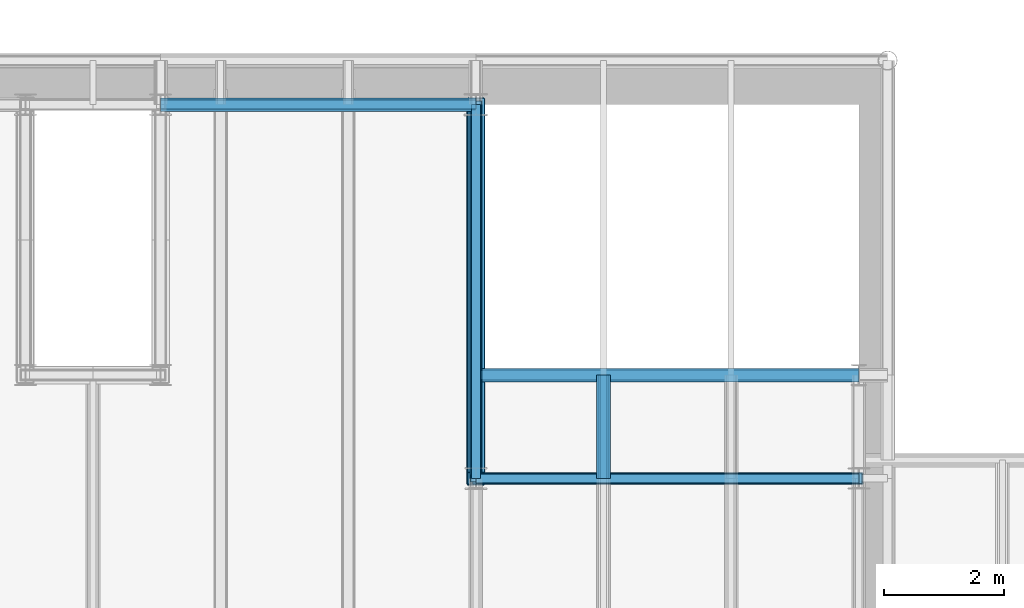
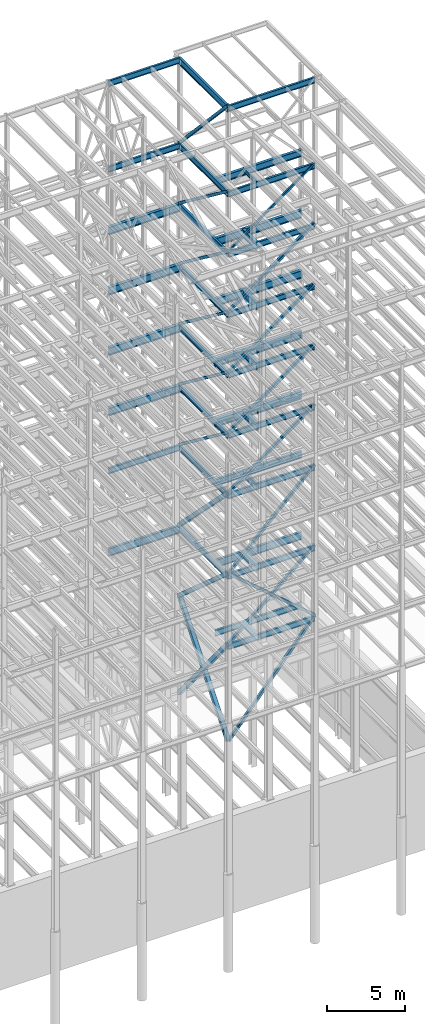
# One storey, part 146 of 150: 60 beams.
"""IFC2X3 building model written with IfcOpenShell, lengths in millimetres."""

from ifc_helpers import new_model, si_unit, frame, origin_with_axes, origin_2d_with_axis, place, context, subcontext, project, spatial, hollow_rectangle, i_section, extrude, material, type_object, element, save


model = new_model("IFC2X3")

# Units and contexts
model_context = context("Model", 3, precision=1e-05, world=origin_with_axes())
body_context = subcontext(model_context, "Body", "Model", "MODEL_VIEW")
ifc_project = project(units=[si_unit("LENGTHUNIT", "METRE", prefix="MILLI"), si_unit("AREAUNIT", "SQUARE_METRE"), si_unit("VOLUMEUNIT", "CUBIC_METRE"), si_unit("MASSUNIT", "GRAM", prefix="KILO"), si_unit("TIMEUNIT", "SECOND"), si_unit("PLANEANGLEUNIT", "RADIAN"), si_unit("SOLIDANGLEUNIT", "STERADIAN"), si_unit("THERMODYNAMICTEMPERATUREUNIT", "DEGREE_CELSIUS"), si_unit("LUMINOUSINTENSITYUNIT", "LUMEN")], contexts=[model_context])

# Site, building, storey
site_placement = place(None, origin_with_axes())
site = spatial("IfcSite", under=ifc_project, at=site_placement, CompositionType="ELEMENT")
building_placement = place(site_placement, origin_with_axes())
building = spatial("IfcBuilding", under=site, at=building_placement, Name="Undefined", CompositionType="ELEMENT")
storey_placement = place(building_placement, origin_with_axes())
storey = spatial("IfcBuildingStorey", under=building, at=storey_placement, Name="Undefined", CompositionType="ELEMENT", Elevation=0.0)

# Beams
ifc_material_1 = material()
beam_type_1 = type_object("IfcBeamType", Name="HSS8X8X3/8", PredefinedType="NOTDEFINED")
for number, where, z_axis, x_axis, name in (
    (1, (82194.4, 25628.6, 40309.8), (-0.593852272176556, 0.0, 0.804574097787607), (0.804574097787604, 0.0, 0.59385227217656), "BEAM"),
    (2, (82194.4, 25628.6, 35585.4), (-0.593852272176556, 0.0, 0.804574097787607), (0.804574097787604, 0.0, 0.59385227217656), "BEAM"),
):
    element("IfcBeam", number, at=place(storey_placement, frame(where, z_axis=z_axis, x_axis=x_axis)), inside=storey, type_object=beam_type_1, material=ifc_material_1, Name=name, ObjectType="HSS8X8X3/8", context=body_context, shape_type="SweptSolid", body=[
        extrude(hollow_rectangle(XDim=203.2, YDim=203.2, WallThickness=9.525, InnerFilletRadius=9.5249, OuterFilletRadius=19.0499, at=origin_2d_with_axis()), frame((7955.51355978985, 0.0, -1.81898940354586e-12), z_axis=(-1.0, 0.0, 0.0), x_axis=(0.0, -1.0, 0.0)), (0.0, 0.0, 1.0), 7955.51355978984),
    ])
ifc_material_2 = material(Name="STEEL/A992")
beam_type_2 = type_object("IfcBeamType", Name="W18X35", PredefinedType="NOTDEFINED")
beam_1_placement = place(storey_placement, frame((82194.4, 25628.6, 65687.575), z_axis=(0.0, 0.0, 1.0), x_axis=(1.0, 0.0, 0.0)))
element("IfcBeam", 3, at=beam_1_placement, inside=storey, type_object=beam_type_2, material=ifc_material_2, Name="BEAM", ObjectType="W18X35", context=body_context, shape_type="SweptSolid", body=[
    extrude(i_section(OverallWidth=152.4, OverallDepth=450.85, WebThickness=7.9375, FlangeThickness=10.795, FilletRadius=17.78, at=origin_2d_with_axis()), frame((6400.80000000001, 0.0, 0.0), z_axis=(-1.0, 0.0, 0.0), x_axis=(0.0, -1.0, 0.0)), (0.0, 0.0, 1.0), 6400.8),
])
beam_2_placement = place(storey_placement, frame((76923.9, 31877.0, 65687.575), z_axis=(0.0, 0.0, 1.0), x_axis=(1.0, 0.0, 0.0)))
element("IfcBeam", 4, at=beam_2_placement, inside=storey, type_object=beam_type_2, material=ifc_material_2, Name="BEAM", ObjectType="W18X35", context=body_context, shape_type="SweptSolid", body=[
    extrude(i_section(OverallWidth=152.4, OverallDepth=450.85, WebThickness=7.9375, FlangeThickness=10.795, FilletRadius=17.78, at=origin_2d_with_axis()), frame((5270.5, 0.0, 0.0), z_axis=(-1.0, 0.0, 0.0), x_axis=(0.0, -1.0, 0.0)), (0.0, 0.0, 1.0), 5270.5),
])
beam_3_placement = place(storey_placement, frame((82194.4, 25628.6, 58981.975), z_axis=(0.0, 0.0, 1.0), x_axis=(1.0, 0.0, 0.0)))
element("IfcBeam", 5, at=beam_3_placement, inside=storey, type_object=beam_type_2, material=ifc_material_2, Name="BEAM", ObjectType="W18X35", context=body_context, shape_type="SweptSolid", body=[
    extrude(i_section(OverallWidth=152.4, OverallDepth=450.85, WebThickness=7.9375, FlangeThickness=10.795, FilletRadius=17.78, at=origin_2d_with_axis()), frame((6400.80000000001, 0.0, 0.0), z_axis=(-1.0, 0.0, 0.0), x_axis=(0.0, -1.0, 0.0)), (0.0, 0.0, 1.0), 6400.8),
])
beam_4_placement = place(storey_placement, frame((82194.4, 25628.6, 58981.975), z_axis=(0.0, 0.0, 1.0), x_axis=(0.0, 1.0, 0.0)))
element("IfcBeam", 6, at=beam_4_placement, inside=storey, type_object=beam_type_2, material=ifc_material_2, Name="BEAM", ObjectType="W18X35", context=body_context, shape_type="SweptSolid", body=[
    extrude(i_section(OverallWidth=152.4, OverallDepth=450.85, WebThickness=7.9375, FlangeThickness=10.795, FilletRadius=17.78, at=origin_2d_with_axis()), frame((6248.40000000001, 0.0, 0.0), z_axis=(-1.0, 0.0, 0.0), x_axis=(0.0, -1.0, 0.0)), (0.0, 0.0, 1.0), 6248.40000000001),
])
beam_5_placement = place(storey_placement, frame((76923.9, 31877.0, 58981.975), z_axis=(0.0, 0.0, 1.0), x_axis=(1.0, 0.0, 0.0)))
element("IfcBeam", 7, at=beam_5_placement, inside=storey, type_object=beam_type_2, material=ifc_material_2, Name="BEAM", ObjectType="W18X35", context=body_context, shape_type="SweptSolid", body=[
    extrude(i_section(OverallWidth=152.4, OverallDepth=450.85, WebThickness=7.9375, FlangeThickness=10.795, FilletRadius=17.78, at=origin_2d_with_axis()), frame((5270.5, 0.0, 0.0), z_axis=(-1.0, 0.0, 0.0), x_axis=(0.0, -1.0, 0.0)), (0.0, 0.0, 1.0), 5270.5),
])
beam_6_placement = place(storey_placement, frame((82194.4, 25628.6, 54257.575), z_axis=(0.0, 0.0, 1.0), x_axis=(1.0, 0.0, 0.0)))
element("IfcBeam", 8, at=beam_6_placement, inside=storey, type_object=beam_type_2, material=ifc_material_2, Name="BEAM", ObjectType="W18X35", context=body_context, shape_type="SweptSolid", body=[
    extrude(i_section(OverallWidth=152.4, OverallDepth=450.85, WebThickness=7.9375, FlangeThickness=10.795, FilletRadius=17.78, at=origin_2d_with_axis()), frame((6400.80000000001, 0.0, 0.0), z_axis=(-1.0, 0.0, 0.0), x_axis=(0.0, -1.0, 0.0)), (0.0, 0.0, 1.0), 6400.8),
])
beam_7_placement = place(storey_placement, frame((82194.4, 31877.0, 54257.575), z_axis=(0.0, 0.0, 1.0), x_axis=(0.0, -1.0, 0.0)))
element("IfcBeam", 9, at=beam_7_placement, inside=storey, type_object=beam_type_2, material=ifc_material_2, Name="BEAM", ObjectType="W18X35", context=body_context, shape_type="SweptSolid", body=[
    extrude(i_section(OverallWidth=152.4, OverallDepth=450.85, WebThickness=7.9375, FlangeThickness=10.795, FilletRadius=17.78, at=origin_2d_with_axis()), frame((6248.40000000001, 0.0, 0.0), z_axis=(-1.0, 0.0, 0.0), x_axis=(0.0, -1.0, 0.0)), (0.0, 0.0, 1.0), 6248.40000000001),
])
beam_8_placement = place(storey_placement, frame((82194.4, 25628.6, 49533.175), z_axis=(0.0, 0.0, 1.0), x_axis=(1.0, 0.0, 0.0)))
element("IfcBeam", 10, at=beam_8_placement, inside=storey, type_object=beam_type_2, material=ifc_material_2, Name="BEAM", ObjectType="W18X35", context=body_context, shape_type="SweptSolid", body=[
    extrude(i_section(OverallWidth=152.4, OverallDepth=450.85, WebThickness=7.9375, FlangeThickness=10.795, FilletRadius=17.78, at=origin_2d_with_axis()), frame((6400.80000000001, 0.0, 0.0), z_axis=(-1.0, 0.0, 0.0), x_axis=(0.0, -1.0, 0.0)), (0.0, 0.0, 1.0), 6400.8),
])
beam_9_placement = place(storey_placement, frame((82194.4, 31877.0, 49533.175), z_axis=(0.0, 0.0, 1.0), x_axis=(0.0, -1.0, 0.0)))
element("IfcBeam", 11, at=beam_9_placement, inside=storey, type_object=beam_type_2, material=ifc_material_2, Name="BEAM", ObjectType="W18X35", context=body_context, shape_type="SweptSolid", body=[
    extrude(i_section(OverallWidth=152.4, OverallDepth=450.85, WebThickness=7.9375, FlangeThickness=10.795, FilletRadius=17.78, at=origin_2d_with_axis()), frame((6248.40000000001, 0.0, 0.0), z_axis=(-1.0, 0.0, 0.0), x_axis=(0.0, -1.0, 0.0)), (0.0, 0.0, 1.0), 6248.40000000001),
])
beam_10_placement = place(storey_placement, frame((82194.4, 25628.6, 44808.775), z_axis=(0.0, 0.0, 1.0), x_axis=(1.0, 0.0, 0.0)))
element("IfcBeam", 12, at=beam_10_placement, inside=storey, type_object=beam_type_2, material=ifc_material_2, Name="BEAM", ObjectType="W18X35", context=body_context, shape_type="SweptSolid", body=[
    extrude(i_section(OverallWidth=152.4, OverallDepth=450.85, WebThickness=7.9375, FlangeThickness=10.795, FilletRadius=17.78, at=origin_2d_with_axis()), frame((6400.80000000001, 0.0, 0.0), z_axis=(-1.0, 0.0, 0.0), x_axis=(0.0, -1.0, 0.0)), (0.0, 0.0, 1.0), 6400.8),
])
beam_11_placement = place(storey_placement, frame((82194.4, 31877.0, 44808.775), z_axis=(0.0, 0.0, 1.0), x_axis=(0.0, -1.0, 0.0)))
element("IfcBeam", 13, at=beam_11_placement, inside=storey, type_object=beam_type_2, material=ifc_material_2, Name="BEAM", ObjectType="W18X35", context=body_context, shape_type="SweptSolid", body=[
    extrude(i_section(OverallWidth=152.4, OverallDepth=450.85, WebThickness=7.9375, FlangeThickness=10.795, FilletRadius=17.78, at=origin_2d_with_axis()), frame((6248.40000000001, 0.0, 0.0), z_axis=(-1.0, 0.0, 0.0), x_axis=(0.0, -1.0, 0.0)), (0.0, 0.0, 1.0), 6248.40000000001),
])
beam_12_placement = place(storey_placement, frame((82194.4, 25628.6, 40084.375), z_axis=(0.0, 0.0, 1.0), x_axis=(1.0, 0.0, 0.0)))
element("IfcBeam", 14, at=beam_12_placement, inside=storey, type_object=beam_type_2, material=ifc_material_2, Name="BEAM", ObjectType="W18X35", context=body_context, shape_type="SweptSolid", body=[
    extrude(i_section(OverallWidth=152.4, OverallDepth=450.85, WebThickness=7.9375, FlangeThickness=10.795, FilletRadius=17.78, at=origin_2d_with_axis()), frame((6400.80000000001, 0.0, 0.0), z_axis=(-1.0, 0.0, 0.0), x_axis=(0.0, -1.0, 0.0)), (0.0, 0.0, 1.0), 6400.8),
])
beam_13_placement = place(storey_placement, frame((82194.4, 31877.0, 40084.375), z_axis=(0.0, 0.0, 1.0), x_axis=(0.0, -1.0, 0.0)))
element("IfcBeam", 15, at=beam_13_placement, inside=storey, type_object=beam_type_2, material=ifc_material_2, Name="BEAM", ObjectType="W18X35", context=body_context, shape_type="SweptSolid", body=[
    extrude(i_section(OverallWidth=152.4, OverallDepth=450.85, WebThickness=7.9375, FlangeThickness=10.795, FilletRadius=17.78, at=origin_2d_with_axis()), frame((6248.40000000001, 0.0, 0.0), z_axis=(-1.0, 0.0, 0.0), x_axis=(0.0, -1.0, 0.0)), (0.0, 0.0, 1.0), 6248.40000000001),
])
beam_14_placement = place(storey_placement, frame((82194.4, 25628.6, 35359.975), z_axis=(0.0, 0.0, 1.0), x_axis=(1.0, 0.0, 0.0)))
element("IfcBeam", 16, at=beam_14_placement, inside=storey, type_object=beam_type_2, material=ifc_material_2, Name="BEAM", ObjectType="W18X35", context=body_context, shape_type="SweptSolid", body=[
    extrude(i_section(OverallWidth=152.4, OverallDepth=450.85, WebThickness=7.9375, FlangeThickness=10.795, FilletRadius=17.78, at=origin_2d_with_axis()), frame((6400.80000000001, 0.0, 0.0), z_axis=(-1.0, 0.0, 0.0), x_axis=(0.0, -1.0, 0.0)), (0.0, 0.0, 1.0), 6400.8),
])
beam_15_placement = place(storey_placement, frame((82194.4, 31877.0, 35359.975), z_axis=(0.0, 0.0, 1.0), x_axis=(0.0, -1.0, 0.0)))
element("IfcBeam", 17, at=beam_15_placement, inside=storey, type_object=beam_type_2, material=ifc_material_2, Name="BEAM", ObjectType="W18X35", context=body_context, shape_type="SweptSolid", body=[
    extrude(i_section(OverallWidth=152.4, OverallDepth=450.85, WebThickness=7.9375, FlangeThickness=10.795, FilletRadius=17.78, at=origin_2d_with_axis()), frame((6248.40000000001, 0.0, 0.0), z_axis=(-1.0, 0.0, 0.0), x_axis=(0.0, -1.0, 0.0)), (0.0, 0.0, 1.0), 6248.40000000001),
])
beam_16_placement = place(storey_placement, frame((76923.9, 31877.0, 35359.975), z_axis=(0.0, 0.0, 1.0), x_axis=(1.0, 0.0, 0.0)))
element("IfcBeam", 18, at=beam_16_placement, inside=storey, type_object=beam_type_2, material=ifc_material_2, Name="BEAM", ObjectType="W18X35", context=body_context, shape_type="SweptSolid", body=[
    extrude(i_section(OverallWidth=152.4, OverallDepth=450.85, WebThickness=7.9375, FlangeThickness=10.795, FilletRadius=17.78, at=origin_2d_with_axis()), frame((5270.5, 0.0, 0.0), z_axis=(-1.0, 0.0, 0.0), x_axis=(0.0, -1.0, 0.0)), (0.0, 0.0, 1.0), 5270.5),
])
beam_17_placement = place(storey_placement, frame((82194.4, 25628.6, 29060.775), z_axis=(0.0, 0.0, 1.0), x_axis=(1.0, 0.0, 0.0)))
element("IfcBeam", 19, at=beam_17_placement, inside=storey, type_object=beam_type_2, material=ifc_material_2, Name="BEAM", ObjectType="W18X35", context=body_context, shape_type="SweptSolid", body=[
    extrude(i_section(OverallWidth=152.4, OverallDepth=450.85, WebThickness=7.9375, FlangeThickness=10.795, FilletRadius=17.78, at=origin_2d_with_axis()), frame((6400.80000000001, 0.0, 0.0), z_axis=(-1.0, 0.0, 0.0), x_axis=(0.0, -1.0, 0.0)), (0.0, 0.0, 1.0), 6400.8),
])
beam_18_placement = place(storey_placement, frame((82194.4, 25628.6, 29060.775), z_axis=(0.0, 0.0, 1.0), x_axis=(0.0, 1.0, 0.0)))
element("IfcBeam", 20, at=beam_18_placement, inside=storey, type_object=beam_type_2, material=ifc_material_2, Name="BEAM", ObjectType="W18X35", context=body_context, shape_type="SweptSolid", body=[
    extrude(i_section(OverallWidth=152.4, OverallDepth=450.85, WebThickness=7.9375, FlangeThickness=10.795, FilletRadius=17.78, at=origin_2d_with_axis()), frame((6248.40000000001, 0.0, 0.0), z_axis=(-1.0, 0.0, 0.0), x_axis=(0.0, -1.0, 0.0)), (0.0, 0.0, 1.0), 6248.40000000001),
])
beam_19_placement = place(storey_placement, frame((82194.4, 27355.8, 23548.975), z_axis=(0.0, 0.0, 1.0), x_axis=(1.0, 0.0, 0.0)))
element("IfcBeam", 21, at=beam_19_placement, inside=storey, type_object=beam_type_2, material=ifc_material_2, Name="BEAM", ObjectType="W18X35", context=body_context, shape_type="SweptSolid", body=[
    extrude(i_section(OverallWidth=152.4, OverallDepth=450.85, WebThickness=7.9375, FlangeThickness=10.795, FilletRadius=17.78, at=origin_2d_with_axis()), frame((6400.80000000001, 0.0, 0.0), z_axis=(-1.0, 0.0, 0.0), x_axis=(0.0, -1.0, 0.0)), (0.0, 0.0, 1.0), 6400.8),
])
beam_20_placement = place(storey_placement, frame((84328.0, 25628.6, 23548.975), z_axis=(0.0, 0.0, 1.0), x_axis=(0.0, 1.0, 0.0)))
element("IfcBeam", 22, at=beam_20_placement, inside=storey, type_object=beam_type_2, material=ifc_material_2, Name="BEAM", ObjectType="W18X35", context=body_context, shape_type="SweptSolid", body=[
    extrude(i_section(OverallWidth=152.4, OverallDepth=450.85, WebThickness=7.9375, FlangeThickness=10.795, FilletRadius=17.78, at=origin_2d_with_axis()), frame((1727.2, 0.0, 0.0), z_axis=(-1.0, 0.0, 0.0), x_axis=(0.0, -1.0, 0.0)), (0.0, 0.0, 1.0), 1727.2),
])
beam_21_placement = place(storey_placement, frame((82194.4, 25628.6, 23548.975), z_axis=(0.0, 0.0, 1.0), x_axis=(1.0, 0.0, 0.0)))
element("IfcBeam", 23, at=beam_21_placement, inside=storey, type_object=beam_type_2, material=ifc_material_2, Name="BEAM", ObjectType="W18X35", context=body_context, shape_type="SweptSolid", body=[
    extrude(i_section(OverallWidth=152.4, OverallDepth=450.85, WebThickness=7.9375, FlangeThickness=10.795, FilletRadius=17.78, at=origin_2d_with_axis()), frame((6400.80000000001, 0.0, 0.0), z_axis=(-1.0, 0.0, 0.0), x_axis=(0.0, -1.0, 0.0)), (0.0, 0.0, 1.0), 6400.8),
])
beam_type_3 = type_object("IfcBeamType", Name="HSS8X8X1/4", PredefinedType="NOTDEFINED")
beam_22_placement = place(storey_placement, frame((82194.4, 31877.0, 59207.4), z_axis=(0.0, 0.73160793181113, 0.681725629642191), x_axis=(0.0, -0.681725629642191, 0.731607931811129)))
element("IfcBeam", 24, at=beam_22_placement, inside=storey, type_object=beam_type_3, material=ifc_material_1, Name="BEAM", ObjectType="HSS8X8X1/4", context=body_context, shape_type="SweptSolid", body=[
    extrude(hollow_rectangle(XDim=203.2, YDim=203.2, WallThickness=6.35, InnerFilletRadius=6.3499, OuterFilletRadius=12.6999, at=origin_2d_with_axis()), frame((9165.56427236196, 0.0, -1.0175820488858e-12), z_axis=(-1.0, 0.0, 0.0), x_axis=(0.0, -1.0, 0.0)), (0.0, 0.0, 1.0), 9165.56427236196),
])
for number, where, z_axis, x_axis, name in (
    (25, (82194.4, 31877.0, 54483.0), (0.0, 0.603108242282795, 0.797659355922412), (0.0, -0.797659355922412, 0.603108242282795), "BEAM"),
    (26, (82194.4, 31877.0, 49758.6), (0.0, 0.603108242282795, 0.797659355922412), (0.0, -0.797659355922412, 0.603108242282795), "BEAM"),
):
    element("IfcBeam", number, at=place(storey_placement, frame(where, z_axis=z_axis, x_axis=x_axis)), inside=storey, type_object=beam_type_3, material=ifc_material_1, Name=name, ObjectType="HSS8X8X1/4", context=body_context, shape_type="SweptSolid", body=[
        extrude(hollow_rectangle(XDim=203.2, YDim=203.2, WallThickness=6.35, InnerFilletRadius=6.3499, OuterFilletRadius=12.6999, at=origin_2d_with_axis()), frame((7833.41929938644, 0.0, 0.0), z_axis=(-1.0, 0.0, 0.0), x_axis=(0.0, -1.0, 0.0)), (0.0, 0.0, 1.0), 7833.41929938644),
    ])
for number, where, z_axis, x_axis, name in (
    (27, (82194.4, 25628.6, 49758.6), (-0.593852272176556, 0.0, 0.804574097787607), (0.804574097787604, 0.0, 0.59385227217656), "BEAM"),
    (28, (82194.4, 25628.6, 45034.2), (-0.593852272176556, 0.0, 0.804574097787607), (0.804574097787604, 0.0, 0.59385227217656), "BEAM"),
):
    element("IfcBeam", number, at=place(storey_placement, frame(where, z_axis=z_axis, x_axis=x_axis)), inside=storey, type_object=beam_type_3, material=ifc_material_1, Name=name, ObjectType="HSS8X8X1/4", context=body_context, shape_type="SweptSolid", body=[
        extrude(hollow_rectangle(XDim=203.2, YDim=203.2, WallThickness=6.35, InnerFilletRadius=6.3499, OuterFilletRadius=12.6999, at=origin_2d_with_axis()), frame((7955.51355978985, 0.0, -1.81898940354586e-12), z_axis=(-1.0, 0.0, 0.0), x_axis=(0.0, -1.0, 0.0)), (0.0, 0.0, 1.0), 7955.51355978984),
    ])
beam_type_4 = type_object("IfcBeamType", Name="HSS12X12X5/8", PredefinedType="NOTDEFINED")
beam_23_placement = place(storey_placement, frame((82194.4, 31877.0, 29286.2), z_axis=(0.0, 0.709963736329935, 0.704238236036952), x_axis=(0.0, -0.704238236036953, 0.709963736329935)))
element("IfcBeam", 29, at=beam_23_placement, inside=storey, type_object=beam_type_4, material=ifc_material_1, Name="BEAM", ObjectType="HSS12X12X5/8", context=body_context, shape_type="SweptSolid", body=[
    extrude(hollow_rectangle(XDim=304.8, YDim=304.8, WallThickness=15.875, InnerFilletRadius=15.875, OuterFilletRadius=31.75, at=origin_2d_with_axis()), frame((8872.56576194282, 0.0, 0.0), z_axis=(-1.0, 0.0, 0.0), x_axis=(0.0, -1.0, 0.0)), (0.0, 0.0, 1.0), 8872.56576194282),
])
beam_24_placement = place(storey_placement, frame((82194.4, 31877.0, 23774.4), z_axis=(0.0, 0.661520808536634, 0.749926809677477), x_axis=(0.0, -0.749926809677476, 0.661520808536635)))
element("IfcBeam", 30, at=beam_24_placement, inside=storey, type_object=beam_type_4, material=ifc_material_1, Name="BEAM", ObjectType="HSS12X12X5/8", context=body_context, shape_type="SweptSolid", body=[
    extrude(hollow_rectangle(XDim=304.8, YDim=304.8, WallThickness=15.875, InnerFilletRadius=15.875, OuterFilletRadius=31.75, at=origin_2d_with_axis()), frame((8332.01307008096, 0.0, -9.25039275188162e-13), z_axis=(-1.0, 0.0, 0.0), x_axis=(0.0, -1.0, 0.0)), (0.0, 0.0, 1.0), 8332.01307008096),
])
for number, where, z_axis, x_axis, name in (
    (31, (82194.4, 25628.6, 16154.4), (0.0, -0.773267797360785, 0.634079579835843), (0.0, 0.634079579835843, 0.773267797360786), "BEAM"),
    (32, (82194.4, 31877.0, 16154.4), (0.0, 0.773267797360785, 0.634079579835843), (0.0, -0.634079579835843, 0.773267797360786), "BEAM"),
):
    element("IfcBeam", number, at=place(storey_placement, frame(where, z_axis=z_axis, x_axis=x_axis)), inside=storey, type_object=beam_type_4, material=ifc_material_1, Name=name, ObjectType="HSS12X12X5/8", context=body_context, shape_type="SweptSolid", body=[
        extrude(hollow_rectangle(XDim=304.8, YDim=304.8, WallThickness=15.875, InnerFilletRadius=15.875, OuterFilletRadius=31.75, at=origin_2d_with_axis()), frame((9854.28346253547, 0.0, 5.47022619564489e-13), z_axis=(-1.0, 0.0, 0.0), x_axis=(0.0, -1.0, 0.0)), (0.0, 0.0, 1.0), 9854.28346253547),
    ])
beam_type_5 = type_object("IfcBeamType", Name="HSS8X8X1/2", PredefinedType="NOTDEFINED")
for number, where, z_axis, x_axis, name in (
    (33, (82194.4, 31877.0, 45034.2), (0.0, 0.603108242282795, 0.797659355922412), (0.0, -0.797659355922412, 0.603108242282795), "BEAM"),
    (34, (82194.4, 31877.0, 40309.8), (0.0, 0.603108242282795, 0.797659355922412), (0.0, -0.797659355922412, 0.603108242282795), "BEAM"),
    (35, (82194.4, 31877.0, 35585.4), (0.0, 0.603108242282795, 0.797659355922412), (0.0, -0.797659355922412, 0.603108242282795), "BEAM"),
):
    element("IfcBeam", number, at=place(storey_placement, frame(where, z_axis=z_axis, x_axis=x_axis)), inside=storey, type_object=beam_type_5, material=ifc_material_1, Name=name, ObjectType="HSS8X8X1/2", context=body_context, shape_type="SweptSolid", body=[
        extrude(hollow_rectangle(XDim=203.2, YDim=203.2, WallThickness=12.7, InnerFilletRadius=12.6999, OuterFilletRadius=25.3999, at=origin_2d_with_axis()), frame((7833.41929938644, 0.0, 0.0), z_axis=(-1.0, 0.0, 0.0), x_axis=(0.0, -1.0, 0.0)), (0.0, 0.0, 1.0), 7833.41929938644),
    ])
beam_25_placement = place(storey_placement, frame((82194.4, 25628.6, 29286.2), z_axis=(-0.701427454200915, 0.0, 0.712740855075127), x_axis=(0.712740855075127, 0.0, 0.701427454200915)))
element("IfcBeam", 36, at=beam_25_placement, inside=storey, type_object=beam_type_5, material=ifc_material_1, Name="BEAM", ObjectType="HSS8X8X1/2", context=body_context, shape_type="SweptSolid", body=[
    extrude(hollow_rectangle(XDim=203.2, YDim=203.2, WallThickness=12.7, InnerFilletRadius=12.6999, OuterFilletRadius=25.3999, at=origin_2d_with_axis()), frame((8980.54348466728, 3.63797880709171e-12, -8.27299822921593e-12), z_axis=(-1.0, 0.0, 0.0), x_axis=(0.0, -1.0, 0.0)), (0.0, 0.0, 1.0), 8980.54348466728),
])
for number, where, z_axis, x_axis, name in (
    (37, (82194.4, 25628.6, 23774.4), (-0.652523116219427, 0.0, 0.75776881883546), (0.757768818835462, 0.0, 0.652523116219425), "BEAM"),
    (38, (88595.2, 25628.6, 23774.4), (0.652523116219427, 0.0, 0.75776881883546), (-0.757768818835462, 0.0, 0.652523116219425), "BEAM"),
):
    element("IfcBeam", number, at=place(storey_placement, frame(where, z_axis=z_axis, x_axis=x_axis)), inside=storey, type_object=beam_type_5, material=ifc_material_1, Name=name, ObjectType="HSS8X8X1/2", context=body_context, shape_type="SweptSolid", body=[
        extrude(hollow_rectangle(XDim=203.2, YDim=203.2, WallThickness=12.7, InnerFilletRadius=12.6999, OuterFilletRadius=25.3999, at=origin_2d_with_axis()), frame((8446.90356758025, 0.0, 0.0), z_axis=(-1.0, 0.0, 0.0), x_axis=(0.0, -1.0, 0.0)), (0.0, 0.0, 1.0), 8446.90356758025),
    ])
beam_26_placement = place(storey_placement, frame((82194.4, 25628.6, 16154.4), z_axis=(-0.765704880549465, 0.0, 0.643192067661542), x_axis=(0.643192067661545, 0.0, 0.765704880549462)))
element("IfcBeam", 39, at=beam_26_placement, inside=storey, type_object=beam_type_5, material=ifc_material_1, Name="BEAM", ObjectType="HSS8X8X1/2", context=body_context, shape_type="SweptSolid", body=[
    extrude(hollow_rectangle(XDim=203.2, YDim=203.2, WallThickness=12.7, InnerFilletRadius=12.6999, OuterFilletRadius=25.3999, at=origin_2d_with_axis()), frame((9951.61497647493, 0.0, 1.1048512079087e-12), z_axis=(-1.0, 0.0, 0.0), x_axis=(0.0, -1.0, 0.0)), (0.0, 0.0, 1.0), 9951.61497647493),
])
beam_type_6 = type_object("IfcBeamType", Name="HSS6X6X1/4", PredefinedType="NOTDEFINED")
beam_27_placement = place(storey_placement, frame((82194.4, 25628.6, 54483.0), z_axis=(-0.593852272176556, 0.0, 0.804574097787607), x_axis=(0.804574097787604, 0.0, 0.59385227217656)))
element("IfcBeam", 40, at=beam_27_placement, inside=storey, type_object=beam_type_6, material=ifc_material_1, Name="BEAM", ObjectType="HSS6X6X1/4", context=body_context, shape_type="SweptSolid", body=[
    extrude(hollow_rectangle(XDim=152.4, YDim=152.4, WallThickness=6.35, InnerFilletRadius=6.3499, OuterFilletRadius=12.6999, at=origin_2d_with_axis()), frame((7955.51355978985, 0.0, -1.81898940354586e-12), z_axis=(-1.0, 0.0, 0.0), x_axis=(0.0, -1.0, 0.0)), (0.0, 0.0, 1.0), 7955.51355978984),
])
beam_type_7 = type_object("IfcBeamType", Name="W21X50", PredefinedType="NOTDEFINED")
beam_28_placement = place(storey_placement, frame((82194.4, 25628.6, 65647.8875), z_axis=(0.0, 0.0, 1.0), x_axis=(0.0, 1.0, 0.0)))
element("IfcBeam", 41, at=beam_28_placement, inside=storey, type_object=beam_type_7, material=ifc_material_2, Name="BEAM", ObjectType="W21X50", context=body_context, shape_type="SweptSolid", body=[
    extrude(i_section(OverallWidth=165.862, OverallDepth=530.225, WebThickness=9.5249, FlangeThickness=13.589, FilletRadius=18.1609, at=origin_2d_with_axis()), frame((6248.40000000001, 0.0, 0.0), z_axis=(-1.0, 0.0, 0.0), x_axis=(0.0, -1.0, 0.0)), (0.0, 0.0, 1.0), 6248.40000000001),
])
beam_type_8 = type_object("IfcBeamType", Name="W24X68", PredefinedType="NOTDEFINED")
beam_29_placement = place(storey_placement, frame((82194.4, 27355.8, 54181.375), z_axis=(0.0, 0.0, 1.0), x_axis=(1.0, 0.0, 0.0)))
element("IfcBeam", 42, at=beam_29_placement, inside=storey, type_object=beam_type_8, material=ifc_material_2, Name="BEAM", ObjectType="W24X68", context=body_context, shape_type="SweptSolid", body=[
    extrude(i_section(OverallWidth=227.838, OverallDepth=603.25, WebThickness=11.1125, FlangeThickness=14.859, FilletRadius=23.2409, at=origin_2d_with_axis()), frame((6400.80000000001, 0.0, 0.0), z_axis=(-1.0, 0.0, 0.0), x_axis=(0.0, -1.0, 0.0)), (0.0, 0.0, 1.0), 6400.8),
])
beam_30_placement = place(storey_placement, frame((76923.9, 31877.0, 54181.375), z_axis=(0.0, 0.0, 1.0), x_axis=(1.0, 0.0, 0.0)))
element("IfcBeam", 43, at=beam_30_placement, inside=storey, type_object=beam_type_8, material=ifc_material_2, Name="BEAM", ObjectType="W24X68", context=body_context, shape_type="SweptSolid", body=[
    extrude(i_section(OverallWidth=227.838, OverallDepth=603.25, WebThickness=11.1125, FlangeThickness=14.859, FilletRadius=23.2409, at=origin_2d_with_axis()), frame((5270.5, 0.0, 0.0), z_axis=(-1.0, 0.0, 0.0), x_axis=(0.0, -1.0, 0.0)), (0.0, 0.0, 1.0), 5270.5),
])
beam_31_placement = place(storey_placement, frame((84328.0, 25628.6, 54181.375), z_axis=(0.0, 0.0, 1.0), x_axis=(0.0, 1.0, 0.0)))
element("IfcBeam", 44, at=beam_31_placement, inside=storey, type_object=beam_type_8, material=ifc_material_2, Name="BEAM", ObjectType="W24X68", context=body_context, shape_type="SweptSolid", body=[
    extrude(i_section(OverallWidth=227.838, OverallDepth=603.25, WebThickness=11.1125, FlangeThickness=14.859, FilletRadius=23.2409, at=origin_2d_with_axis()), frame((1727.2, 0.0, 0.0), z_axis=(-1.0, 0.0, 0.0), x_axis=(0.0, -1.0, 0.0)), (0.0, 0.0, 1.0), 1727.2),
])
beam_32_placement = place(storey_placement, frame((82194.4, 27355.8, 49456.975), z_axis=(0.0, 0.0, 1.0), x_axis=(1.0, 0.0, 0.0)))
element("IfcBeam", 45, at=beam_32_placement, inside=storey, type_object=beam_type_8, material=ifc_material_2, Name="BEAM", ObjectType="W24X68", context=body_context, shape_type="SweptSolid", body=[
    extrude(i_section(OverallWidth=227.838, OverallDepth=603.25, WebThickness=11.1125, FlangeThickness=14.859, FilletRadius=23.2409, at=origin_2d_with_axis()), frame((6400.80000000001, 0.0, 0.0), z_axis=(-1.0, 0.0, 0.0), x_axis=(0.0, -1.0, 0.0)), (0.0, 0.0, 1.0), 6400.8),
])
beam_33_placement = place(storey_placement, frame((76923.9, 31877.0, 49456.975), z_axis=(0.0, 0.0, 1.0), x_axis=(1.0, 0.0, 0.0)))
element("IfcBeam", 46, at=beam_33_placement, inside=storey, type_object=beam_type_8, material=ifc_material_2, Name="BEAM", ObjectType="W24X68", context=body_context, shape_type="SweptSolid", body=[
    extrude(i_section(OverallWidth=227.838, OverallDepth=603.25, WebThickness=11.1125, FlangeThickness=14.859, FilletRadius=23.2409, at=origin_2d_with_axis()), frame((5270.5, 0.0, 0.0), z_axis=(-1.0, 0.0, 0.0), x_axis=(0.0, -1.0, 0.0)), (0.0, 0.0, 1.0), 5270.5),
])
beam_34_placement = place(storey_placement, frame((84328.0, 25628.6, 49456.975), z_axis=(0.0, 0.0, 1.0), x_axis=(0.0, 1.0, 0.0)))
element("IfcBeam", 47, at=beam_34_placement, inside=storey, type_object=beam_type_8, material=ifc_material_2, Name="BEAM", ObjectType="W24X68", context=body_context, shape_type="SweptSolid", body=[
    extrude(i_section(OverallWidth=227.838, OverallDepth=603.25, WebThickness=11.1125, FlangeThickness=14.859, FilletRadius=23.2409, at=origin_2d_with_axis()), frame((1727.2, 0.0, 0.0), z_axis=(-1.0, 0.0, 0.0), x_axis=(0.0, -1.0, 0.0)), (0.0, 0.0, 1.0), 1727.2),
])
beam_35_placement = place(storey_placement, frame((82194.4, 27355.8, 44732.575), z_axis=(0.0, 0.0, 1.0), x_axis=(1.0, 0.0, 0.0)))
element("IfcBeam", 48, at=beam_35_placement, inside=storey, type_object=beam_type_8, material=ifc_material_2, Name="BEAM", ObjectType="W24X68", context=body_context, shape_type="SweptSolid", body=[
    extrude(i_section(OverallWidth=227.838, OverallDepth=603.25, WebThickness=11.1125, FlangeThickness=14.859, FilletRadius=23.2409, at=origin_2d_with_axis()), frame((6400.80000000001, 0.0, 0.0), z_axis=(-1.0, 0.0, 0.0), x_axis=(0.0, -1.0, 0.0)), (0.0, 0.0, 1.0), 6400.8),
])
beam_36_placement = place(storey_placement, frame((76923.9, 31877.0, 44732.575), z_axis=(0.0, 0.0, 1.0), x_axis=(1.0, 0.0, 0.0)))
element("IfcBeam", 49, at=beam_36_placement, inside=storey, type_object=beam_type_8, material=ifc_material_2, Name="BEAM", ObjectType="W24X68", context=body_context, shape_type="SweptSolid", body=[
    extrude(i_section(OverallWidth=227.838, OverallDepth=603.25, WebThickness=11.1125, FlangeThickness=14.859, FilletRadius=23.2409, at=origin_2d_with_axis()), frame((5270.5, 0.0, 0.0), z_axis=(-1.0, 0.0, 0.0), x_axis=(0.0, -1.0, 0.0)), (0.0, 0.0, 1.0), 5270.5),
])
beam_37_placement = place(storey_placement, frame((84328.0, 25628.6, 44732.575), z_axis=(0.0, 0.0, 1.0), x_axis=(0.0, 1.0, 0.0)))
element("IfcBeam", 50, at=beam_37_placement, inside=storey, type_object=beam_type_8, material=ifc_material_2, Name="BEAM", ObjectType="W24X68", context=body_context, shape_type="SweptSolid", body=[
    extrude(i_section(OverallWidth=227.838, OverallDepth=603.25, WebThickness=11.1125, FlangeThickness=14.859, FilletRadius=23.2409, at=origin_2d_with_axis()), frame((1727.2, 0.0, 0.0), z_axis=(-1.0, 0.0, 0.0), x_axis=(0.0, -1.0, 0.0)), (0.0, 0.0, 1.0), 1727.2),
])
beam_38_placement = place(storey_placement, frame((82194.4, 27355.8, 40008.175), z_axis=(0.0, 0.0, 1.0), x_axis=(1.0, 0.0, 0.0)))
element("IfcBeam", 51, at=beam_38_placement, inside=storey, type_object=beam_type_8, material=ifc_material_2, Name="BEAM", ObjectType="W24X68", context=body_context, shape_type="SweptSolid", body=[
    extrude(i_section(OverallWidth=227.838, OverallDepth=603.25, WebThickness=11.1125, FlangeThickness=14.859, FilletRadius=23.2409, at=origin_2d_with_axis()), frame((6400.80000000001, 0.0, 0.0), z_axis=(-1.0, 0.0, 0.0), x_axis=(0.0, -1.0, 0.0)), (0.0, 0.0, 1.0), 6400.8),
])
beam_39_placement = place(storey_placement, frame((76923.9, 31877.0, 40008.175), z_axis=(0.0, 0.0, 1.0), x_axis=(1.0, 0.0, 0.0)))
element("IfcBeam", 52, at=beam_39_placement, inside=storey, type_object=beam_type_8, material=ifc_material_2, Name="BEAM", ObjectType="W24X68", context=body_context, shape_type="SweptSolid", body=[
    extrude(i_section(OverallWidth=227.838, OverallDepth=603.25, WebThickness=11.1125, FlangeThickness=14.859, FilletRadius=23.2409, at=origin_2d_with_axis()), frame((5270.5, 0.0, 0.0), z_axis=(-1.0, 0.0, 0.0), x_axis=(0.0, -1.0, 0.0)), (0.0, 0.0, 1.0), 5270.5),
])
beam_40_placement = place(storey_placement, frame((84328.0, 25628.6, 40008.175), z_axis=(0.0, 0.0, 1.0), x_axis=(0.0, 1.0, 0.0)))
element("IfcBeam", 53, at=beam_40_placement, inside=storey, type_object=beam_type_8, material=ifc_material_2, Name="BEAM", ObjectType="W24X68", context=body_context, shape_type="SweptSolid", body=[
    extrude(i_section(OverallWidth=227.838, OverallDepth=603.25, WebThickness=11.1125, FlangeThickness=14.859, FilletRadius=23.2409, at=origin_2d_with_axis()), frame((1727.2, 0.0, 0.0), z_axis=(-1.0, 0.0, 0.0), x_axis=(0.0, -1.0, 0.0)), (0.0, 0.0, 1.0), 1727.2),
])
beam_type_9 = type_object("IfcBeamType", Name="W21X55", PredefinedType="NOTDEFINED")
beam_41_placement = place(storey_placement, frame((82194.4, 27355.8, 58943.875), z_axis=(0.0, 0.0, 1.0), x_axis=(1.0, 0.0, 0.0)))
element("IfcBeam", 54, at=beam_41_placement, inside=storey, type_object=beam_type_9, material=ifc_material_2, Name="BEAM", ObjectType="W21X55", context=body_context, shape_type="SweptSolid", body=[
    extrude(i_section(OverallWidth=208.788, OverallDepth=527.05, WebThickness=9.5, FlangeThickness=13.2588, FilletRadius=16.8624, at=origin_2d_with_axis()), frame((6400.80000000001, 0.0, 0.0), z_axis=(-1.0, 0.0, 0.0), x_axis=(0.0, -1.0, 0.0)), (0.0, 0.0, 1.0), 6400.8),
])
beam_type_10 = type_object("IfcBeamType", Name="W10X15", PredefinedType="NOTDEFINED")
beam_42_placement = place(storey_placement, frame((84328.0, 25628.6, 59080.4), z_axis=(0.0, 0.0, 1.0), x_axis=(0.0, 1.0, 0.0)))
element("IfcBeam", 55, at=beam_42_placement, inside=storey, type_object=beam_type_10, material=ifc_material_2, Name="BEAM", ObjectType="W10X15", context=body_context, shape_type="SweptSolid", body=[
    extrude(i_section(OverallWidth=101.6, OverallDepth=254.0, WebThickness=6.3499, FlangeThickness=6.858, FilletRadius=13.7795, at=origin_2d_with_axis()), frame((1727.2, 0.0, 0.0), z_axis=(-1.0, 0.0, 0.0), x_axis=(0.0, -1.0, 0.0)), (0.0, 0.0, 1.0), 1727.2),
])
beam_type_11 = type_object("IfcBeamType", Name="W24X55", PredefinedType="NOTDEFINED")
beam_43_placement = place(storey_placement, frame((84328.0, 25628.59968504, 28986.1625), z_axis=(0.0, 0.0, 1.0), x_axis=(0.0, 1.0, 0.0)))
element("IfcBeam", 56, at=beam_43_placement, inside=storey, type_object=beam_type_11, material=ifc_material_2, Name="BEAM", ObjectType="W24X55", context=body_context, shape_type="SweptSolid", body=[
    extrude(i_section(OverallWidth=178.054, OverallDepth=600.075, WebThickness=9.5249, FlangeThickness=12.827, FilletRadius=23.6854, at=origin_2d_with_axis()), frame((1727.20031496001, 0.0, 0.0), z_axis=(-1.0, 0.0, 0.0), x_axis=(0.0, -1.0, 0.0)), (0.0, 0.0, 1.0), 1727.20031496),
])
beam_44_placement = place(storey_placement, frame((82194.4, 27355.8, 28986.1625), z_axis=(0.0, 0.0, 1.0), x_axis=(1.0, 0.0, 0.0)))
element("IfcBeam", 57, at=beam_44_placement, inside=storey, type_object=beam_type_11, material=ifc_material_2, Name="BEAM", ObjectType="W24X55", context=body_context, shape_type="SweptSolid", body=[
    extrude(i_section(OverallWidth=178.054, OverallDepth=600.075, WebThickness=9.5249, FlangeThickness=12.827, FilletRadius=23.6854, at=origin_2d_with_axis()), frame((6400.80000000001, 0.0, 0.0), z_axis=(-1.0, 0.0, 0.0), x_axis=(0.0, -1.0, 0.0)), (0.0, 0.0, 1.0), 6400.8),
])
beam_45_placement = place(storey_placement, frame((76923.9, 31877.0, 28986.1625), z_axis=(0.0, 0.0, 1.0), x_axis=(1.0, 0.0, 0.0)))
element("IfcBeam", 58, at=beam_45_placement, inside=storey, type_object=beam_type_11, material=ifc_material_2, Name="BEAM", ObjectType="W24X55", context=body_context, shape_type="SweptSolid", body=[
    extrude(i_section(OverallWidth=178.054, OverallDepth=600.075, WebThickness=9.5249, FlangeThickness=12.827, FilletRadius=23.6854, at=origin_2d_with_axis()), frame((5270.5, 0.0, 0.0), z_axis=(-1.0, 0.0, 0.0), x_axis=(0.0, -1.0, 0.0)), (0.0, 0.0, 1.0), 5270.5),
])
beam_type_12 = type_object("IfcBeamType", Name="W21X44", PredefinedType="NOTDEFINED")
beam_46_placement = place(storey_placement, frame((84327.99935992, 25628.59968504, 35323.4625), z_axis=(0.0, 0.0, 1.0), x_axis=(0.0, 1.0, 0.0)))
element("IfcBeam", 59, at=beam_46_placement, inside=storey, type_object=beam_type_12, material=ifc_material_2, Name="BEAM", ObjectType="W21X44", context=body_context, shape_type="SweptSolid", body=[
    extrude(i_section(OverallWidth=165.1, OverallDepth=523.875, WebThickness=9.5249, FlangeThickness=11.43, FilletRadius=17.145, at=origin_2d_with_axis()), frame((1727.20031496001, 0.0, 0.0), z_axis=(-1.0, 0.0, 0.0), x_axis=(0.0, -1.0, 0.0)), (0.0, 0.0, 1.0), 1727.20031496001),
])
beam_47_placement = place(storey_placement, frame((82194.4, 27355.8, 35323.4625), z_axis=(0.0, 0.0, 1.0), x_axis=(1.0, 0.0, 0.0)))
element("IfcBeam", 60, at=beam_47_placement, inside=storey, type_object=beam_type_12, material=ifc_material_2, Name="BEAM", ObjectType="W21X44", context=body_context, shape_type="SweptSolid", body=[
    extrude(i_section(OverallWidth=165.1, OverallDepth=523.875, WebThickness=9.5249, FlangeThickness=11.43, FilletRadius=17.145, at=origin_2d_with_axis()), frame((6400.80000000001, 0.0, 0.0), z_axis=(-1.0, 0.0, 0.0), x_axis=(0.0, -1.0, 0.0)), (0.0, 0.0, 1.0), 6400.8),
])

save(model, "model.ifc")
